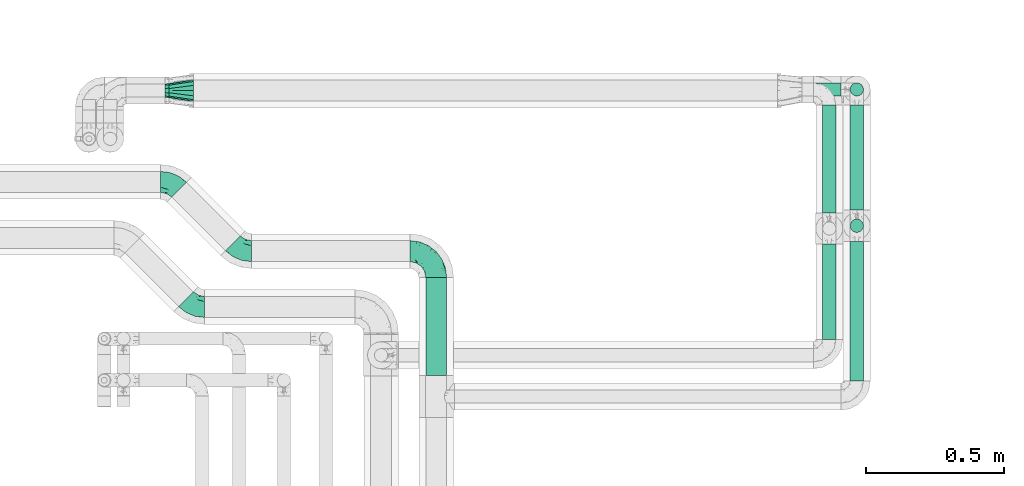
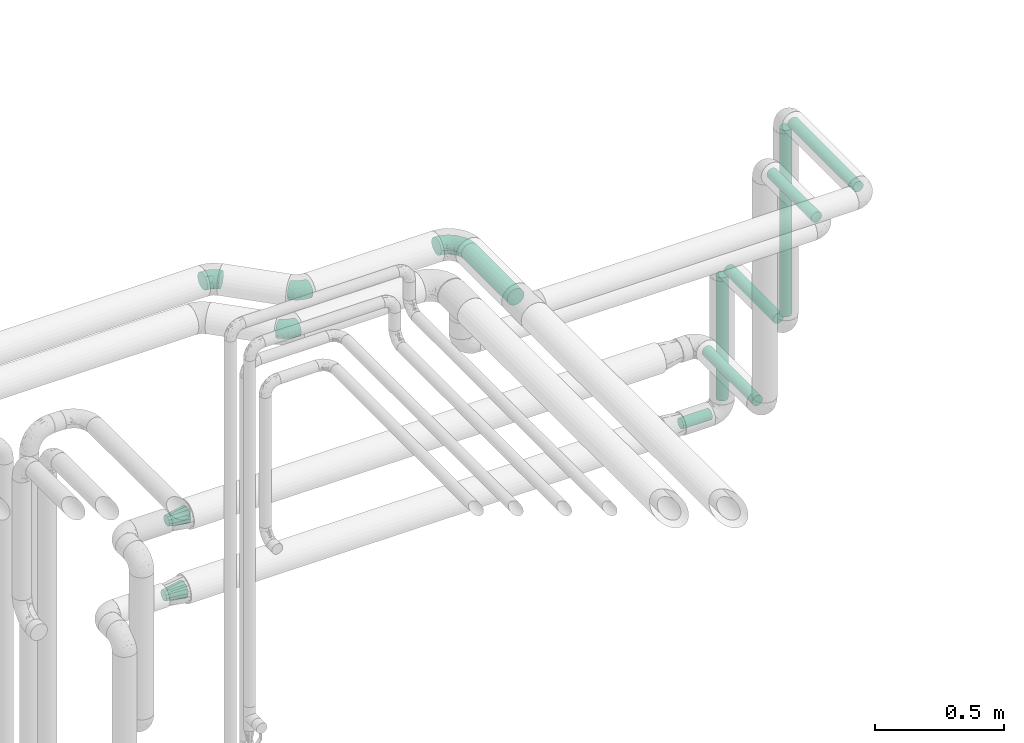
# One storey, part 686 of 827: 8 flow segments, 6 flow fittings.
"""IFC2X3 building model written with IfcOpenShell, lengths in millimetres."""

from ifc_helpers import new_model, entity, si_unit, converted_unit, derived_unit, direction, frame, origin, origin_2d_with_axis, place, context, subcontext, project, spatial, circle, extrude, faceted_brep, source, transform, mapped, material, type_object, type_shapes, element, save


model = new_model("IFC2X3")

# Units and contexts
model_context = context("Model", 3, precision=0.01, world=origin(), true_north=direction((6.12303176911189e-17, 1.0)))
body_context = subcontext(model_context, "Body", "Model", "MODEL_VIEW")
ifc_project = project(units=[si_unit("LENGTHUNIT", "METRE", prefix="MILLI"), si_unit("AREAUNIT", "SQUARE_METRE"), si_unit("VOLUMEUNIT", "CUBIC_METRE"), converted_unit("PLANEANGLEUNIT", "DEGREE", entity("IfcRatioMeasure", 0.0174532925199433), si_unit("PLANEANGLEUNIT", "RADIAN"), dimensions=[0, 0, 0, 0, 0, 0, 0]), si_unit("MASSUNIT", "GRAM", prefix="KILO"), derived_unit("MASSDENSITYUNIT", [(si_unit("MASSUNIT", "GRAM", prefix="KILO"), 1), (si_unit("LENGTHUNIT", "METRE"), -3)]), derived_unit("MOMENTOFINERTIAUNIT", [(si_unit("LENGTHUNIT", "METRE"), 4)]), si_unit("TIMEUNIT", "SECOND"), si_unit("FREQUENCYUNIT", "HERTZ"), si_unit("THERMODYNAMICTEMPERATUREUNIT", "DEGREE_CELSIUS"), derived_unit("THERMALTRANSMITTANCEUNIT", [(si_unit("MASSUNIT", "GRAM", prefix="KILO"), 1), (si_unit("THERMODYNAMICTEMPERATUREUNIT", "KELVIN"), -1), (si_unit("TIMEUNIT", "SECOND"), -3)]), derived_unit("VOLUMETRICFLOWRATEUNIT", [(si_unit("LENGTHUNIT", "METRE"), 3), (si_unit("TIMEUNIT", "SECOND"), -1)]), derived_unit("MASSFLOWRATEUNIT", [(si_unit("MASSUNIT", "GRAM", prefix="KILO"), 1), (si_unit("TIMEUNIT", "SECOND"), -1)]), derived_unit("ROTATIONALFREQUENCYUNIT", [(si_unit("TIMEUNIT", "SECOND"), -1)]), si_unit("ELECTRICCURRENTUNIT", "AMPERE"), si_unit("ELECTRICVOLTAGEUNIT", "VOLT"), si_unit("POWERUNIT", "WATT"), si_unit("FORCEUNIT", "NEWTON", prefix="KILO"), si_unit("ILLUMINANCEUNIT", "LUX"), si_unit("LUMINOUSFLUXUNIT", "LUMEN"), si_unit("LUMINOUSINTENSITYUNIT", "CANDELA"), derived_unit("USERDEFINED", [(si_unit("MASSUNIT", "GRAM", prefix="KILO"), -1), (si_unit("LENGTHUNIT", "METRE"), -2), (si_unit("TIMEUNIT", "SECOND"), 3), (si_unit("LUMINOUSFLUXUNIT", "LUMEN"), 1)]), derived_unit("LINEARVELOCITYUNIT", [(si_unit("LENGTHUNIT", "METRE"), 1), (si_unit("TIMEUNIT", "SECOND"), -1)]), si_unit("PRESSUREUNIT", "PASCAL"), derived_unit("USERDEFINED", [(si_unit("LENGTHUNIT", "METRE"), -2), (si_unit("MASSUNIT", "GRAM", prefix="KILO"), 1), (si_unit("TIMEUNIT", "SECOND"), -2)]), derived_unit("LINEARFORCEUNIT", [(si_unit("MASSUNIT", "GRAM", prefix="KILO"), 1), (si_unit("LENGTHUNIT", "METRE"), 1), (si_unit("TIMEUNIT", "SECOND"), -2), (si_unit("LENGTHUNIT", "METRE"), -1)]), derived_unit("PLANARFORCEUNIT", [(si_unit("MASSUNIT", "GRAM", prefix="KILO"), 1), (si_unit("LENGTHUNIT", "METRE"), 1), (si_unit("TIMEUNIT", "SECOND"), -2), (si_unit("LENGTHUNIT", "METRE"), -2)])], contexts=[model_context])

# Site, building, storey
site_placement = place(None, origin())
site = spatial("IfcSite", under=ifc_project, at=site_placement, CompositionType="ELEMENT")
building_placement = place(site_placement, origin())
building = spatial("IfcBuilding", under=site, at=building_placement, CompositionType="ELEMENT")
storey_placement = place(building_placement, frame((0.0, 0.0, 28200.0)))
storey = spatial("IfcBuildingStorey", under=building, at=storey_placement, Name="08", CompositionType="ELEMENT", Elevation=28200.0)

# Flow segments
pipe_segment_type = type_object("IfcPipeSegmentType", PredefinedType="NOTDEFINED")
flow_segment_1_placement = place(storey_placement, frame((48805.69, 18106.53, 2960.65)))
element("IfcFlowSegment", 1, at=flow_segment_1_placement, inside=storey, type_object=pipe_segment_type, context=body_context, shape_type="SweptSolid", body=[
    extrude(circle(Radius=37.75, at=origin_2d_with_axis()), frame((39.35, 0.0, 39.35), z_axis=(0.0, 1.0, 0.0), x_axis=(-1.0, 0.0, 0.0)), (0.0, 0.0, 1.0), 356.978263748389),
])
flow_segment_2_placement = place(storey_placement, frame((50346.44, 18087.53, 2974.4)))
element("IfcFlowSegment", 2, at=flow_segment_2_placement, inside=storey, type_object=pipe_segment_type, context=body_context, shape_type="SweptSolid", body=[
    extrude(circle(Radius=24.0, at=origin_2d_with_axis()), frame((25.6, 0.0, 25.6), z_axis=(0.0, 1.0, 0.0), x_axis=(1.0, 0.0, 0.0)), (0.0, 0.0, 1.0), 506.000000000015),
])
flow_segment_3_placement = place(storey_placement, frame((50346.44, 18624.93, 2057.0)))
element("IfcFlowSegment", 3, at=flow_segment_3_placement, inside=storey, type_object=pipe_segment_type, context=body_context, shape_type="SweptSolid", body=[
    extrude(circle(Radius=24.0, at=origin_2d_with_axis()), frame((25.6, 25.6, 0.0)), (0.0, 0.0, 1.0), 886.000000000011),
])
flow_segment_4_placement = place(storey_placement, frame((50246.44, 18237.53, 2774.4)))
element("IfcFlowSegment", 4, at=flow_segment_4_placement, inside=storey, type_object=pipe_segment_type, context=body_context, shape_type="SweptSolid", body=[
    extrude(circle(Radius=24.0, at=origin_2d_with_axis()), frame((25.6, 0.0, 25.6), z_axis=(0.0, 1.0, 0.0), x_axis=(1.0, 0.0, 0.0)), (0.0, 0.0, 1.0), 345.999999999956),
])
flow_segment_5_placement = place(storey_placement, frame((50346.44, 18707.53, 1974.4)))
element("IfcFlowSegment", 5, at=flow_segment_5_placement, inside=storey, type_object=pipe_segment_type, context=body_context, shape_type="SweptSolid", body=[
    extrude(circle(Radius=24.0, at=origin_2d_with_axis()), frame((25.6, 0.0, 25.6), z_axis=(0.0, 1.0, 0.0), x_axis=(1.0, 0.0, 0.0)), (0.0, 0.0, 1.0), 381.000000000009),
])
flow_segment_6_placement = place(storey_placement, frame((50346.44, 19119.93, 1357.0)))
element("IfcFlowSegment", 6, at=flow_segment_6_placement, inside=storey, type_object=pipe_segment_type, context=body_context, shape_type="SweptSolid", body=[
    extrude(circle(Radius=24.0, at=origin_2d_with_axis()), frame((25.6, 25.6, 0.0)), (0.0, 0.0, 1.0), 586.00000000001),
])
flow_segment_7_placement = place(storey_placement, frame((50185.03, 19119.93, 1274.4)))
element("IfcFlowSegment", 7, at=flow_segment_7_placement, inside=storey, type_object=pipe_segment_type, context=body_context, shape_type="SweptSolid", body=[
    extrude(circle(Radius=24.0, at=origin_2d_with_axis()), frame((0.0, 25.6, 25.6), z_axis=(1.0, 0.0, 0.0), x_axis=(0.0, 1.0, 0.0)), (0.0, 0.0, 1.0), 130.000000000005),
])
flow_segment_8_placement = place(storey_placement, frame((50246.44, 18697.53, 1624.4)))
element("IfcFlowSegment", 8, at=flow_segment_8_placement, inside=storey, type_object=pipe_segment_type, context=body_context, shape_type="SweptSolid", body=[
    extrude(circle(Radius=24.0, at=origin_2d_with_axis()), frame((25.6, 0.0, 25.6), z_axis=(0.0, 1.0, 0.0), x_axis=(1.0, 0.0, 0.0)), (0.0, 0.0, 1.0), 390.99999997821),
])

# Flow fittings
ifc_material = material()
pipe_fitting_type_1 = type_object("IfcPipeFittingType", Name="ADSK_1", PredefinedType="NOTDEFINED", material=ifc_material)
shared_shape_1 = source(origin(), body_context, "Body", "Brep", [
    faceted_brep([(-95.0, 19.02, -32.95), (-95.0, 9.85, -36.75), (-95.0, 0.0, -38.05), (-95.0, -9.85, -36.75), (-95.0, -19.03, -32.95), (-95.0, -26.91, -26.91), (-95.0, -32.95, -19.03), (-95.0, -36.75, -9.85), (-95.0, -38.05, 0.0), (-95.0, -36.75, 9.85), (-95.0, -32.95, 19.02), (-95.0, -26.91, 26.91), (-95.0, -19.03, 32.95), (-95.0, -9.85, 36.75), (-95.0, 0.0, 38.05), (-95.0, 9.85, 36.75), (-95.0, 19.02, 32.95), (-95.0, 26.91, 26.91), (-95.0, 32.95, 19.02), (-95.0, 36.75, 9.85), (-95.0, 38.05, 0.0), (-95.0, 36.75, -9.85), (-95.0, 32.95, -19.03), (-95.0, 26.91, -26.91), (0.0, 95.0, -38.05), (-9.85, 95.0, -36.75), (-19.02, 95.0, -32.95), (-26.91, 95.0, -26.91), (-32.95, 95.0, -19.03), (-36.75, 95.0, -9.85), (-38.05, 95.0, 0.0), (-36.75, 95.0, 9.85), (-32.95, 95.0, 19.02), (-26.91, 95.0, 26.91), (-19.02, 95.0, 32.95), (-9.85, 95.0, 36.75), (0.0, 95.0, 38.05), (9.85, 95.0, 36.75), (19.03, 95.0, 32.95), (26.91, 95.0, 26.91), (32.95, 95.0, 19.02), (36.75, 95.0, 9.85), (38.05, 95.0, 0.0), (36.75, 95.0, -9.85), (32.95, 95.0, -19.03), (26.91, 95.0, -26.91), (19.03, 95.0, -32.95), (9.85, 95.0, -36.75), (-7.99, -4.96, 6.3), (-0.92, 0.92, 0.0), (4.62, 8.1, 8.01), (-76.19, -35.57, 0.0), (-64.32, -32.32, 12.43), (20.51, 62.45, 28.68), (-60.56, -33.52, 0.0), (-70.4, -13.47, 34.42), (-39.61, -5.88, 32.32), (-49.6, 2.07, 37.1), (-70.34, -28.81, 21.71), (14.64, 40.81, 26.5), (5.88, 39.61, 32.32), (3.59, 20.77, 25.31), (-40.45, 68.06, 16.75), (-62.45, -20.51, 28.68), (-44.52, -26.87, 0.0), (-28.47, -20.22, 0.0), (-26.43, -17.83, 8.75), (-76.1, 39.63, 10.76), (-72.74, 37.58, 18.19), (-60.35, 46.18, 14.61), (-13.4, 13.4, 32.12), (-20.77, -3.59, 25.31), (-14.66, 81.47, 35.56), (-6.22, 71.26, 37.92), (-57.5, 42.48, 22.79), (-15.0, 34.74, 37.7), (-27.1, 12.08, 36.05), (-9.2, 28.81, 35.63), (-79.98, 23.7, 30.95), (-73.68, -4.3, 37.48), (-30.74, 21.67, 37.97), (-62.36, 47.59, 6.79), (-72.71, 32.83, 24.69), (-67.42, 7.02, 37.95), (-32.13, 75.27, 24.51), (-43.46, 51.47, 26.26), (-24.98, 73.15, 31.29), (20.59, 41.28, 19.85), (7.79, 16.09, 15.86), (-73.21, 42.39, 0.0), (-54.73, 54.73, 0.0), (-73.44, 15.79, 35.79), (-5.94, 4.32, 20.43), (28.81, 70.34, 21.71), (32.32, 64.32, 12.43), (-53.59, 26.2, 35.09), (-52.02, 19.31, 37.21), (21.38, 33.53, 10.34), (26.87, 44.52, 0.0), (-48.28, 12.14, 38.05), (4.3, 73.68, 37.48), (-44.08, -25.52, 12.79), (-41.28, -20.59, 19.85), (35.57, 76.19, 0.0), (-47.26, 54.3, 20.18), (-47.4, 61.99, 8.58), (-42.39, 73.21, 0.0), (-39.67, 78.86, 7.21), (-45.69, 36.84, 33.11), (-32.83, 50.13, 33.35), (13.47, 70.4, 34.42), (-18.25, 63.73, 36.07), (-40.63, -13.75, 27.22), (-16.63, 46.37, 37.95), (-53.47, 38.79, 28.59), (-26.07, 48.54, 36.15), (-34.51, 34.51, 36.86), (-2.07, 49.6, 37.1), (-22.79, -10.49, 19.23), (-61.73, 28.67, 31.87), (9.65, 14.7, 0.0), (20.22, 28.47, 0.0), (33.52, 60.56, 0.0), (-11.42, -5.44, 13.25), (-14.7, -9.65, 0.0), (-81.47, 14.66, -35.56), (-62.45, -20.51, -28.68), (-71.26, 6.22, -37.92), (-75.27, 32.13, -24.51), (-73.15, 24.98, -31.29), (13.47, 70.4, -34.42), (5.88, 39.61, -32.32), (-2.07, 49.6, -37.1), (-78.86, 39.67, -7.21), (-70.4, -13.47, -34.42), (-39.61, -5.88, -32.32), (-61.99, 47.4, -8.58), (32.32, 64.32, -12.43), (28.81, 70.34, -21.71), (-63.73, 18.25, -36.07), (-50.13, 32.83, -33.35), (4.3, 73.68, -37.48), (-7.02, 67.42, -37.95), (-39.63, 76.1, -10.76), (-46.18, 60.35, -14.61), (-47.59, 62.36, -6.79), (-64.32, -32.32, -12.43), (-26.2, 53.59, -35.09), (-15.79, 73.44, -35.79), (-19.31, 52.02, -37.21), (-37.58, 72.74, -18.19), (-70.34, -28.81, -21.71), (-42.48, 57.5, -22.79), (-38.79, 53.47, -28.59), (-51.47, 43.46, -26.26), (-32.83, 72.71, -24.69), (-46.37, 16.63, -37.95), (-73.68, -4.3, -37.48), (-41.28, -20.59, -19.85), (-44.08, -25.52, -12.79), (13.75, 40.63, -27.22), (20.51, 62.45, -28.68), (-68.06, 40.45, -16.75), (-54.3, 47.26, -20.18), (-12.14, 48.28, -38.05), (-21.67, 30.74, -37.97), (-36.84, 45.69, -33.11), (-11.42, -5.44, -13.25), (7.79, 16.09, -15.86), (4.62, 8.1, -8.01), (-23.7, 79.98, -30.95), (-26.43, -17.83, -8.75), (-7.99, -4.96, -6.3), (-40.81, -14.64, -26.5), (-20.77, -3.59, -25.31), (-34.74, 15.0, -37.7), (-12.08, 27.1, -36.05), (-28.81, 9.2, -35.63), (-22.79, -10.49, -19.23), (21.38, 33.53, -10.34), (20.59, 41.28, -19.85), (-48.54, 26.07, -36.15), (-49.6, 2.07, -37.1), (-13.4, 13.4, -32.12), (3.59, 20.77, -25.31), (-28.67, 61.73, -31.87), (-34.51, 34.51, -36.86), (-5.94, 4.32, -20.43)], [[[0, 1, 2, 3, 4, 5, 6, 7, 8, 9, 10, 11, 12, 13, 14, 15, 16, 17, 18, 19, 20, 21, 22, 23]], [[24, 25, 26, 27, 28, 29, 30, 31, 32, 33, 34, 35, 36, 37, 38, 39, 40, 41, 42, 43, 44, 45, 46, 47]], [[48, 49, 50]], [[51, 52, 9]], [[53, 39, 38]], [[9, 52, 10]], [[54, 52, 51]], [[55, 56, 57]], [[11, 10, 58]], [[59, 60, 61]], [[32, 31, 62]], [[63, 12, 11]], [[63, 55, 12]], [[64, 65, 66]], [[67, 68, 69]], [[70, 56, 71]], [[35, 72, 73]], [[69, 68, 74]], [[75, 76, 77]], [[16, 78, 17]], [[13, 79, 14]], [[76, 75, 80]], [[67, 69, 81]], [[18, 17, 82]], [[14, 79, 83]], [[20, 19, 67]], [[84, 85, 86]], [[87, 61, 88]], [[89, 81, 90]], [[18, 82, 68]], [[15, 91, 16]], [[14, 83, 15]], [[71, 92, 61]], [[17, 78, 82]], [[93, 87, 94]], [[95, 91, 96]], [[97, 98, 94]], [[86, 72, 34]], [[96, 99, 80]], [[37, 36, 100]], [[40, 39, 93]], [[40, 94, 41]], [[64, 66, 101]], [[93, 94, 40]], [[58, 102, 63]], [[94, 103, 41]], [[94, 87, 97]], [[104, 69, 74]], [[34, 33, 86]], [[105, 69, 104]], [[52, 58, 10]], [[106, 107, 30]], [[108, 109, 85]], [[105, 106, 90]], [[53, 110, 60]], [[86, 111, 72]], [[86, 109, 111]], [[33, 84, 86]], [[12, 55, 13]], [[112, 56, 63]], [[110, 38, 37]], [[34, 72, 35]], [[36, 35, 73]], [[111, 113, 73]], [[105, 107, 106]], [[110, 53, 38]], [[74, 114, 85]], [[91, 15, 83]], [[105, 90, 81]], [[107, 62, 31]], [[33, 32, 84]], [[115, 109, 116]], [[111, 115, 113]], [[100, 73, 117]], [[56, 55, 63]], [[79, 55, 57]], [[102, 118, 112]], [[56, 70, 76]], [[100, 110, 37]], [[117, 77, 60]], [[117, 60, 110]], [[60, 70, 61]], [[58, 52, 101]], [[63, 11, 58]], [[39, 53, 93]], [[87, 93, 53]], [[96, 91, 83]], [[78, 91, 119]], [[32, 62, 84]], [[84, 62, 104]], [[86, 85, 109]], [[85, 114, 108]], [[80, 113, 116]], [[117, 73, 113]], [[80, 116, 96]], [[80, 57, 76]], [[71, 112, 118]], [[61, 87, 59]], [[62, 107, 105]], [[97, 120, 121]], [[70, 71, 61]], [[71, 118, 92]], [[73, 100, 36]], [[110, 100, 117]], [[55, 79, 13]], [[83, 79, 57]], [[96, 83, 99]], [[116, 108, 95]], [[50, 97, 88]], [[97, 87, 88]], [[50, 49, 120]], [[122, 94, 98]], [[89, 20, 67]], [[105, 81, 69]], [[89, 67, 81]], [[68, 19, 18]], [[68, 67, 19]], [[74, 68, 82]], [[114, 82, 119]], [[74, 85, 104]], [[82, 114, 74]], [[114, 119, 108]], [[95, 108, 119]], [[116, 109, 108]], [[123, 48, 50]], [[97, 50, 120]], [[123, 50, 88]], [[91, 95, 119]], [[116, 95, 96]], [[84, 104, 85]], [[104, 62, 105]], [[83, 57, 99]], [[57, 80, 99]], [[66, 48, 123]], [[66, 124, 48]], [[118, 66, 123]], [[124, 66, 65]], [[66, 118, 101]], [[54, 64, 52]], [[124, 49, 48]], [[30, 107, 31]], [[91, 78, 16]], [[82, 78, 119]], [[56, 76, 57]], [[77, 76, 70]], [[60, 77, 70]], [[77, 117, 75]], [[117, 113, 75]], [[113, 80, 75]], [[9, 8, 51]], [[103, 94, 122]], [[103, 42, 41]], [[73, 72, 111]], [[113, 115, 116]], [[111, 109, 115]], [[102, 112, 63]], [[71, 56, 112]], [[118, 102, 101]], [[92, 123, 88]], [[123, 92, 118]], [[61, 92, 88]], [[87, 53, 59]], [[60, 59, 53]], [[97, 121, 98]], [[58, 101, 102]], [[64, 101, 52]], [[125, 1, 0]], [[126, 5, 4]], [[2, 1, 127]], [[1, 125, 127]], [[128, 129, 23]], [[130, 131, 132]], [[89, 133, 20]], [[126, 134, 135]], [[136, 89, 90]], [[137, 138, 44]], [[139, 129, 140]], [[24, 141, 142]], [[143, 144, 145]], [[125, 129, 139]], [[6, 146, 7]], [[147, 148, 149]], [[146, 51, 7]], [[143, 150, 144]], [[146, 6, 151]], [[152, 153, 154]], [[126, 4, 134]], [[0, 23, 129]], [[28, 155, 150]], [[43, 42, 103]], [[54, 146, 64]], [[139, 156, 127]], [[157, 3, 2]], [[151, 158, 159]], [[160, 131, 161]], [[22, 21, 162]], [[136, 144, 163]], [[149, 164, 165]], [[24, 142, 25]], [[166, 140, 154]], [[154, 129, 128]], [[143, 30, 29]], [[167, 168, 169]], [[155, 28, 27]], [[26, 170, 27]], [[171, 167, 172]], [[26, 25, 148]], [[27, 170, 155]], [[173, 135, 174]], [[144, 150, 152]], [[175, 176, 177]], [[24, 47, 141]], [[45, 161, 46]], [[148, 25, 142]], [[176, 175, 165]], [[64, 159, 171]], [[138, 45, 44]], [[130, 46, 161]], [[137, 44, 43]], [[178, 159, 158]], [[137, 103, 122]], [[163, 144, 152]], [[136, 133, 89]], [[103, 137, 43]], [[6, 5, 151]], [[178, 158, 173]], [[134, 4, 3]], [[178, 173, 174]], [[137, 98, 179]], [[145, 90, 106]], [[138, 180, 161]], [[46, 130, 47]], [[136, 90, 145]], [[133, 162, 21]], [[23, 22, 128]], [[139, 140, 181]], [[139, 181, 156]], [[157, 127, 182]], [[157, 134, 3]], [[182, 177, 135]], [[182, 135, 134]], [[135, 183, 174]], [[131, 130, 161]], [[141, 130, 132]], [[160, 180, 184]], [[131, 183, 176]], [[5, 126, 151]], [[158, 151, 126]], [[180, 138, 137]], [[161, 45, 138]], [[149, 148, 142]], [[170, 148, 185]], [[22, 162, 128]], [[128, 162, 163]], [[129, 154, 140]], [[154, 153, 166]], [[165, 156, 186]], [[182, 127, 156]], [[165, 186, 149]], [[165, 132, 176]], [[131, 184, 183]], [[187, 167, 178]], [[184, 168, 187]], [[167, 169, 172]], [[184, 180, 168]], [[174, 183, 184]], [[127, 157, 2]], [[134, 157, 182]], [[130, 141, 47]], [[142, 141, 132]], [[149, 142, 164]], [[186, 166, 147]], [[180, 179, 168]], [[169, 179, 120]], [[137, 179, 180]], [[179, 121, 120]], [[106, 30, 143]], [[136, 145, 144]], [[106, 143, 145]], [[150, 29, 28]], [[150, 143, 29]], [[152, 150, 155]], [[153, 155, 185]], [[152, 154, 163]], [[155, 153, 152]], [[153, 185, 166]], [[147, 166, 185]], [[186, 140, 166]], [[169, 120, 49]], [[169, 49, 172]], [[179, 169, 168]], [[148, 147, 185]], [[186, 147, 149]], [[128, 163, 154]], [[163, 162, 136]], [[142, 132, 164]], [[132, 165, 164]], [[171, 124, 65]], [[124, 171, 172]], [[64, 146, 159]], [[171, 159, 178]], [[171, 65, 64]], [[172, 49, 124]], [[162, 133, 136]], [[20, 133, 21]], [[148, 170, 26]], [[155, 170, 185]], [[131, 176, 132]], [[177, 176, 183]], [[135, 177, 183]], [[177, 182, 175]], [[182, 156, 175]], [[156, 165, 175]], [[51, 146, 54]], [[51, 8, 7]], [[129, 125, 0]], [[127, 125, 139]], [[140, 186, 181]], [[156, 181, 186]], [[158, 126, 173]], [[135, 173, 126]], [[187, 178, 174]], [[171, 178, 167]], [[184, 187, 174]], [[167, 187, 168]], [[180, 160, 161]], [[184, 131, 160]], [[98, 137, 122]], [[98, 121, 179]], [[151, 159, 146]]]),
])
type_shapes(pipe_fitting_type_1, [shared_shape_1])
flow_fitting_1_placement = place(storey_placement, frame((48845.03, 18558.51, 3000.0), z_axis=(0.0, 0.0, 1.0), x_axis=(0.0, 1.0, 0.0)))
element("IfcFlowFitting", 9, at=flow_fitting_1_placement, inside=storey, type_object=pipe_fitting_type_1, material=ifc_material, Name="ADSK_1", ObjectType="ADSK_1", context=body_context, shape_type="MappedRepresentation", body=[
    mapped(shared_shape_1, transform((0.0, 0.0, 0.0), scale=1.0)),
])
pipe_fitting_type_2 = type_object("IfcPipeFittingType", Name="ADSK_1", PredefinedType="NOTDEFINED", material=ifc_material)
shared_shape_2 = source(origin(), body_context, "Body", "Brep", [
    faceted_brep([(-39.35, 19.02, -32.95), (-39.35, 9.85, -36.75), (-39.35, 0.0, -38.05), (-39.35, -9.85, -36.75), (-39.35, -19.03, -32.95), (-39.35, -26.91, -26.91), (-39.35, -32.95, -19.03), (-39.35, -36.75, -9.85), (-39.35, -38.05, 0.0), (-39.35, -36.75, 9.85), (-39.35, -32.95, 19.02), (-39.35, -26.91, 26.91), (-39.35, -19.03, 32.95), (-39.35, -9.85, 36.75), (-39.35, 0.0, 38.05), (-39.35, 9.85, 36.75), (-39.35, 19.02, 32.95), (-39.35, 26.91, 26.91), (-39.35, 32.95, 19.02), (-39.35, 36.75, 9.85), (-39.35, 38.05, 0.0), (-39.35, 36.75, -9.85), (-39.35, 32.95, -19.03), (-39.35, 26.91, -26.91), (27.82, 27.82, -38.05), (20.86, 34.79, -36.75), (14.37, 41.28, -32.95), (8.8, 46.85, -26.91), (4.52, 51.13, -19.03), (1.84, 53.81, -9.85), (0.92, 54.73, 0.0), (1.84, 53.81, 9.85), (4.52, 51.13, 19.02), (8.8, 46.85, 26.91), (14.37, 41.28, 32.95), (20.86, 34.79, 36.75), (27.82, 27.82, 38.05), (34.79, 20.86, 36.75), (41.28, 14.37, 32.95), (46.85, 8.8, 26.91), (51.13, 4.52, 19.02), (53.81, 1.84, 9.85), (54.73, 0.92, 0.0), (53.81, 1.84, -9.85), (51.13, 4.52, -19.03), (46.85, 8.8, -26.91), (41.28, 14.37, -32.95), (34.79, 20.86, -36.75), (-16.48, -28.6, 22.48), (-9.83, -32.19, 13.52), (8.97, -21.66, 21.67), (-20.54, -35.57, 0.0), (-4.91, -33.52, 0.0), (-13.54, -34.93, 6.65), (-11.41, -20.66, 29.54), (31.88, -8.57, 22.48), (-19.69, -13.48, 34.86), (3.15, -7.61, 34.49), (12.7, 20.76, 37.8), (-14.37, -2.8, 37.58), (-4.35, 10.49, 37.89), (-23.66, 5.7, 37.8), (22.68, -6.54, 29.54), (23.46, 4.39, 34.86), (-17.67, 16.65, 35.5), (-11.48, 27.71, 30.93), (-5.05, 36.47, 26.65), (11.57, -24.66, 14.82), (11.29, -27.26, 7.35), (-19.91, 32.6, 23.86), (-16.29, 39.33, 15.52), (34.27, -15.12, 6.65), (39.68, -10.63, 0.0), (-13.09, 43.52, 7.94), (12.14, 8.18, 37.58), (29.72, -15.81, 13.52), (2.92, 25.68, 35.46), (5.55, -13.39, 30.82), (-17.56, 42.39, 0.0), (-7.75, 40.18, 21.01), (11.13, -26.87, 0.0), (27.17, -20.22, 0.0), (-14.37, -2.8, -37.58), (-13.54, -34.93, -6.65), (11.26, -27.2, -7.7), (0.72, 24.27, -35.5), (-23.66, 5.7, -37.8), (-21.52, 40.03, -7.94), (-16.29, 39.33, -15.52), (22.68, -6.54, -29.54), (-22.21, 29.36, -26.65), (29.72, -15.81, -13.52), (-22.93, 33.89, -21.01), (-8.97, 37.13, -23.86), (12.14, 8.18, -37.58), (-20.22, 16.09, -35.46), (-9.83, -32.19, -13.52), (31.88, -8.57, -22.48), (-16.48, -28.6, -22.48), (8.97, -21.66, -21.67), (8.74, -25.75, -14.99), (-11.41, -20.66, -29.54), (5.55, -13.39, -30.82), (3.15, -7.61, -34.49), (-19.69, -13.48, -34.86), (-11.48, 27.71, -30.93), (34.27, -15.12, -6.65), (12.7, 20.76, -37.8), (23.46, 4.39, -34.86), (-4.35, 10.49, -37.89)], [[[0, 1, 2, 3, 4, 5, 6, 7, 8, 9, 10, 11, 12, 13, 14, 15, 16, 17, 18, 19, 20, 21, 22, 23]], [[24, 25, 26, 27, 28, 29, 30, 31, 32, 33, 34, 35, 36, 37, 38, 39, 40, 41, 42, 43, 44, 45, 46, 47]], [[48, 49, 50]], [[51, 52, 53]], [[12, 11, 54]], [[40, 39, 55]], [[56, 54, 57]], [[48, 11, 10]], [[36, 35, 58]], [[13, 12, 56]], [[59, 60, 61]], [[14, 13, 59]], [[62, 55, 39]], [[38, 37, 63]], [[61, 15, 14]], [[16, 64, 65]], [[9, 51, 53]], [[33, 66, 34]], [[67, 49, 68]], [[65, 17, 16]], [[18, 17, 69]], [[18, 69, 70]], [[19, 18, 70]], [[41, 71, 72]], [[73, 20, 19]], [[52, 68, 53]], [[49, 53, 68]], [[16, 15, 64]], [[36, 58, 74]], [[39, 38, 62]], [[57, 74, 59]], [[74, 37, 36]], [[66, 69, 65]], [[75, 40, 55]], [[60, 58, 76]], [[62, 38, 63]], [[17, 65, 69]], [[71, 41, 75]], [[49, 48, 10]], [[61, 64, 15]], [[77, 50, 62]], [[19, 70, 73]], [[10, 9, 49]], [[78, 73, 30]], [[48, 54, 11]], [[31, 73, 70]], [[57, 63, 74]], [[69, 66, 79]], [[55, 62, 50]], [[79, 70, 69]], [[56, 59, 13]], [[35, 34, 76]], [[76, 65, 64]], [[54, 77, 57]], [[60, 59, 74]], [[75, 41, 40]], [[54, 48, 50]], [[32, 31, 70]], [[75, 55, 50]], [[65, 76, 34]], [[60, 76, 64]], [[54, 56, 12]], [[59, 56, 57]], [[74, 63, 37]], [[62, 63, 57]], [[9, 8, 51]], [[68, 52, 80, 81]], [[9, 53, 49]], [[71, 68, 81]], [[68, 75, 67]], [[72, 71, 81]], [[72, 42, 41]], [[68, 71, 75]], [[59, 61, 14]], [[64, 61, 60]], [[76, 58, 35]], [[74, 58, 60]], [[30, 73, 31]], [[73, 78, 20]], [[50, 77, 54]], [[62, 57, 77]], [[34, 66, 65]], [[79, 33, 32]], [[33, 79, 66]], [[32, 70, 79]], [[75, 50, 67]], [[49, 67, 50]], [[3, 2, 82]], [[52, 83, 84]], [[26, 25, 85]], [[2, 1, 86]], [[21, 87, 88]], [[46, 45, 89]], [[0, 23, 90]], [[44, 43, 91]], [[92, 88, 93]], [[24, 47, 94]], [[29, 28, 88]], [[1, 0, 95]], [[83, 7, 96]], [[91, 97, 44]], [[98, 99, 100]], [[98, 96, 6]], [[5, 4, 101]], [[89, 102, 103]], [[7, 6, 96]], [[5, 98, 6]], [[104, 4, 3]], [[90, 93, 105]], [[101, 98, 5]], [[28, 27, 93]], [[20, 78, 87]], [[27, 105, 93]], [[30, 29, 87]], [[102, 99, 101]], [[105, 85, 95]], [[88, 22, 21]], [[28, 93, 88]], [[104, 101, 4]], [[85, 105, 26]], [[90, 92, 93]], [[86, 82, 2]], [[27, 26, 105]], [[43, 72, 106]], [[107, 25, 24]], [[108, 47, 46]], [[7, 83, 51]], [[44, 97, 45]], [[103, 108, 89]], [[97, 89, 45]], [[109, 107, 94]], [[99, 97, 91]], [[109, 94, 82]], [[106, 72, 81]], [[108, 94, 47]], [[103, 104, 82]], [[83, 96, 84]], [[103, 82, 94]], [[100, 91, 84]], [[107, 85, 25]], [[29, 88, 87]], [[109, 86, 95]], [[98, 101, 99]], [[89, 97, 99]], [[105, 95, 0]], [[109, 95, 85]], [[82, 104, 3]], [[101, 104, 103]], [[89, 108, 46]], [[94, 108, 103]], [[51, 83, 52]], [[51, 8, 7]], [[100, 84, 96]], [[106, 84, 91]], [[84, 81, 80, 52]], [[43, 42, 72]], [[84, 106, 81]], [[43, 106, 91]], [[95, 86, 1]], [[82, 86, 109]], [[94, 107, 24]], [[85, 107, 109]], [[20, 87, 21]], [[87, 78, 30]], [[99, 102, 89]], [[101, 103, 102]], [[0, 90, 105]], [[92, 23, 22]], [[23, 92, 90]], [[22, 88, 92]], [[98, 100, 96]], [[91, 100, 99]]]),
])
type_shapes(pipe_fitting_type_2, [shared_shape_2])
for number, where, z_axis, x_axis, name in (
    (10, (47964.84, 18355.68, 3000.0), (0.0, 0.0, 1.0), (0.707106781186551, -0.707106781186544, 0.0), "ADSK_1"),
    (11, (48135.03, 18558.51, 3000.0), (0.0, 0.0, 1.0), (0.707106781186538, -0.707106781186558, 0.0), "ADSK_1"),
    (12, (47883.72, 18809.82, 3000.0), (0.0, 0.0, 1.0), (-0.707106781186505, 0.70710678118659, 0.0), "ADSK_1"),
):
    element("IfcFlowFitting", number, at=place(storey_placement, frame(where, z_axis=z_axis, x_axis=x_axis)), inside=storey, type_object=pipe_fitting_type_2, material=ifc_material, Name=name, ObjectType="ADSK_1", context=body_context, shape_type="MappedRepresentation", body=[
        mapped(shared_shape_2, transform((0.0, 0.0, 0.0), scale=1.0)),
    ])
pipe_fitting_type_3 = type_object("IfcPipeFittingType", Name="ADSK_1", PredefinedType="NOTDEFINED", material=ifc_material)
shared_shape_3 = source(origin(), body_context, "Body", "Brep", [
    faceted_brep([(89.0, 24.15, 0.0), (89.0, 21.84, 7.1), (89.0, 19.54, 14.2), (89.0, 13.5, 18.58), (89.0, 7.46, 22.97), (89.0, 0.0, 22.97), (89.0, -7.46, 22.97), (89.0, -13.5, 18.58), (89.0, -19.54, 14.2), (89.0, -21.84, 7.1), (89.0, -24.15, 0.0), (89.0, -21.84, -7.1), (89.0, -19.54, -14.2), (89.0, -13.5, -18.58), (89.0, -7.46, -22.97), (89.0, 0.0, -22.97), (89.0, 7.46, -22.97), (89.0, 13.5, -18.58), (89.0, 19.54, -14.2), (89.0, 21.84, -7.1), (0.0, 25.99, 25.99), (0.0, 32.95, 19.02), (0.0, 36.21, 6.85), (0.0, 38.05, 0.0), (0.0, 36.21, -6.85), (0.0, 32.95, -19.03), (0.0, 25.99, -25.99), (0.0, 19.03, -32.95), (0.0, 9.51, -35.5), (0.0, 0.0, -38.05), (0.0, -9.51, -35.5), (0.0, -19.03, -32.95), (0.0, -25.99, -25.99), (0.0, -32.95, -19.02), (0.0, -36.21, -6.85), (0.0, -38.05, 0.0), (0.0, -36.21, 6.85), (0.0, -32.95, 19.02), (0.0, -25.99, 25.99), (0.0, -19.02, 32.95), (0.0, -9.51, 35.5), (0.0, 0.0, 38.05), (0.0, 9.51, 35.5), (0.0, 19.02, 32.95)], [[[0, 1, 2, 3, 4, 5, 6, 7, 8, 9, 10, 11, 12, 13, 14, 15, 16, 17, 18, 19]], [[20, 21, 22, 23, 24, 25, 26, 27, 28, 29, 30, 31, 32, 33, 34, 35, 36, 37, 38, 39, 40, 41, 42, 43]], [[26, 17, 27]], [[25, 18, 26]], [[17, 26, 18]], [[25, 19, 18]], [[24, 0, 19]], [[31, 14, 13]], [[17, 16, 27]], [[28, 27, 16]], [[14, 30, 15]], [[16, 15, 28]], [[12, 32, 13]], [[10, 35, 34]], [[30, 29, 15]], [[10, 34, 11]], [[25, 24, 19]], [[14, 31, 30]], [[0, 24, 23]], [[11, 33, 12]], [[12, 33, 32]], [[33, 11, 34]], [[31, 13, 32]], [[28, 15, 29]], [[38, 7, 39]], [[37, 8, 38]], [[7, 38, 8]], [[37, 9, 8]], [[36, 10, 9]], [[43, 4, 3]], [[7, 6, 39]], [[40, 39, 6]], [[4, 42, 5]], [[6, 5, 40]], [[2, 20, 3]], [[0, 23, 22]], [[42, 41, 5]], [[0, 22, 1]], [[37, 36, 9]], [[4, 43, 42]], [[10, 36, 35]], [[1, 21, 2]], [[2, 21, 20]], [[21, 1, 22]], [[43, 3, 20]], [[40, 5, 41]]]),
])
type_shapes(pipe_fitting_type_3, [shared_shape_3])
flow_fitting_2_placement = place(storey_placement, frame((47950.3, 19141.22, 1300.0), z_axis=(0.0, 0.0, 1.0), x_axis=(-1.0, 0.0, 0.0)))
element("IfcFlowFitting", 13, at=flow_fitting_2_placement, inside=storey, type_object=pipe_fitting_type_3, material=ifc_material, Name="ADSK_1", ObjectType="ADSK_1", context=body_context, shape_type="MappedRepresentation", body=[
    mapped(shared_shape_3, transform((0.0, 0.0, 0.0), scale=1.0)),
])
pipe_fitting_type_4 = type_object("IfcPipeFittingType", Name="ADSK_1", PredefinedType="NOTDEFINED", material=ifc_material)
shared_shape_4 = source(origin(), body_context, "Body", "Brep", [
    faceted_brep([(89.0, -38.05, 0.0), (89.0, -36.21, -6.85), (89.0, -32.95, -19.02), (89.0, -25.99, -25.99), (89.0, -19.03, -32.95), (89.0, -9.51, -35.5), (89.0, 0.0, -38.05), (89.0, 9.51, -35.5), (89.0, 19.02, -32.95), (89.0, 25.99, -25.99), (89.0, 32.95, -19.02), (89.0, 36.21, -6.85), (89.0, 38.05, 0.0), (89.0, 36.21, 6.85), (89.0, 32.95, 19.03), (89.0, 25.99, 25.99), (89.0, 19.02, 32.95), (89.0, 9.51, 35.5), (89.0, 0.0, 38.05), (89.0, -9.51, 35.5), (89.0, -19.03, 32.95), (89.0, -25.99, 25.99), (89.0, -32.95, 19.03), (89.0, -36.21, 6.85), (0.0, 24.15, 0.0), (0.0, 21.84, -7.1), (0.0, 19.54, -14.2), (0.0, 13.5, -18.58), (0.0, 7.46, -22.97), (0.0, 0.0, -22.97), (0.0, -7.46, -22.97), (0.0, -13.5, -18.58), (0.0, -19.54, -14.2), (0.0, -21.84, -7.1), (0.0, -24.15, 0.0), (0.0, -21.84, 7.1), (0.0, -19.54, 14.2), (0.0, -13.5, 18.58), (0.0, -7.46, 22.97), (0.0, 0.0, 22.97), (0.0, 7.46, 22.97), (0.0, 13.5, 18.58), (0.0, 19.54, 14.2), (0.0, 21.84, 7.1)], [[[0, 1, 2, 3, 4, 5, 6, 7, 8, 9, 10, 11, 12, 13, 14, 15, 16, 17, 18, 19, 20, 21, 22, 23]], [[24, 25, 26, 27, 28, 29, 30, 31, 32, 33, 34, 35, 36, 37, 38, 39, 40, 41, 42, 43]], [[2, 33, 32]], [[28, 7, 29]], [[29, 5, 30]], [[24, 12, 11]], [[3, 32, 31]], [[34, 1, 0]], [[1, 34, 33]], [[8, 28, 27]], [[2, 1, 33]], [[31, 4, 3]], [[2, 32, 3]], [[11, 25, 24]], [[26, 10, 9]], [[10, 25, 11]], [[28, 8, 7]], [[27, 26, 9]], [[26, 25, 10]], [[31, 30, 4]], [[8, 27, 9]], [[29, 7, 6]], [[5, 29, 6]], [[5, 4, 30]], [[14, 43, 42]], [[38, 19, 39]], [[39, 17, 40]], [[34, 0, 23]], [[15, 42, 41]], [[24, 13, 12]], [[13, 24, 43]], [[20, 38, 37]], [[14, 13, 43]], [[41, 16, 15]], [[14, 42, 15]], [[23, 35, 34]], [[36, 22, 21]], [[22, 35, 23]], [[38, 20, 19]], [[37, 36, 21]], [[36, 35, 22]], [[41, 40, 16]], [[20, 37, 21]], [[39, 19, 18]], [[17, 39, 18]], [[17, 16, 40]]]),
])
type_shapes(pipe_fitting_type_4, [shared_shape_4])
flow_fitting_3_placement = place(storey_placement, frame((47874.3, 19141.22, 1650.0)))
element("IfcFlowFitting", 14, at=flow_fitting_3_placement, inside=storey, type_object=pipe_fitting_type_4, material=ifc_material, Name="ADSK_1", ObjectType="ADSK_1", context=body_context, shape_type="MappedRepresentation", body=[
    mapped(shared_shape_4, transform((0.0, 0.0, 0.0), scale=1.0)),
])

save(model, "model.ifc")
